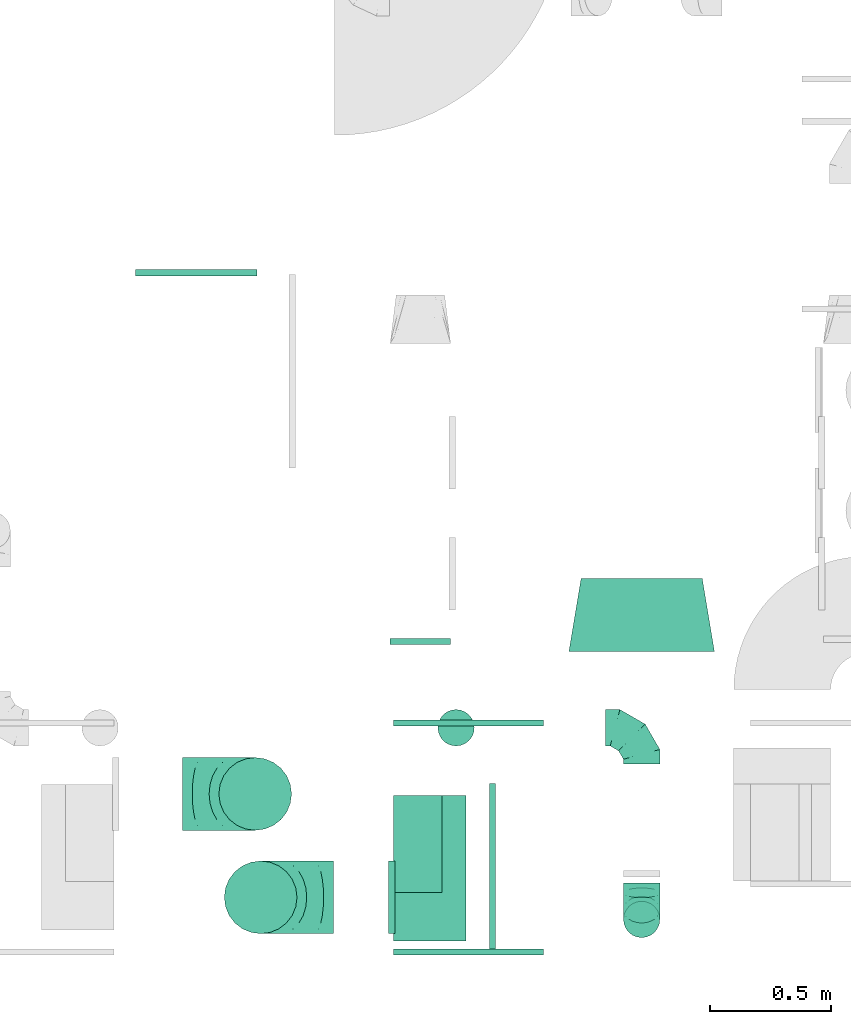
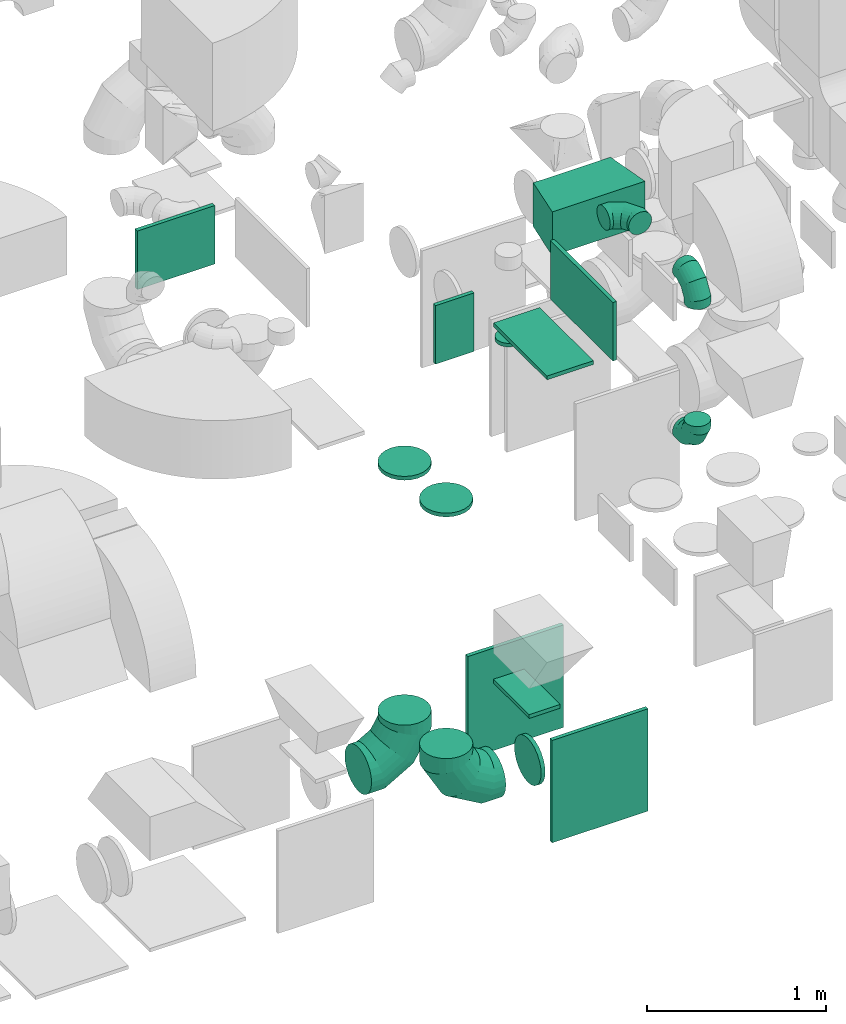
# One storey, part 22 of 59: 17 flow fittings.
"""IFC2X3 building model written with IfcOpenShell, lengths in millimetres."""

from ifc_helpers import new_model, entity, si_unit, converted_unit, derived_unit, direction, frame, origin, origin_2d_with_axis, place, context, subcontext, project, spatial, polyline, rectangle, circle, outline, extrude, faceted_brep, source, transform, mapped, material, type_object, type_shapes, element, save


model = new_model("IFC2X3")

# Units and contexts
model_context = context("Model", 3, precision=0.01, world=origin(), true_north=direction((6.12303176911189e-17, 1.0)))
body_context = subcontext(model_context, "Body", "Model", "MODEL_VIEW")
ifc_project = project(units=[si_unit("LENGTHUNIT", "METRE", prefix="MILLI"), si_unit("AREAUNIT", "SQUARE_METRE"), si_unit("VOLUMEUNIT", "CUBIC_METRE"), converted_unit("PLANEANGLEUNIT", "DEGREE", entity("IfcRatioMeasure", 0.0174532925199433), si_unit("PLANEANGLEUNIT", "RADIAN"), dimensions=[0, 0, 0, 0, 0, 0, 0]), si_unit("MASSUNIT", "GRAM", prefix="KILO"), derived_unit("MASSDENSITYUNIT", [(si_unit("MASSUNIT", "GRAM", prefix="KILO"), 1), (si_unit("LENGTHUNIT", "METRE"), -3)]), derived_unit("MOMENTOFINERTIAUNIT", [(si_unit("LENGTHUNIT", "METRE"), 4)]), si_unit("TIMEUNIT", "SECOND"), si_unit("FREQUENCYUNIT", "HERTZ"), si_unit("THERMODYNAMICTEMPERATUREUNIT", "DEGREE_CELSIUS"), derived_unit("THERMALTRANSMITTANCEUNIT", [(si_unit("MASSUNIT", "GRAM", prefix="KILO"), 1), (si_unit("THERMODYNAMICTEMPERATUREUNIT", "KELVIN"), -1), (si_unit("TIMEUNIT", "SECOND"), -3)]), derived_unit("VOLUMETRICFLOWRATEUNIT", [(si_unit("LENGTHUNIT", "METRE"), 3), (si_unit("TIMEUNIT", "SECOND"), -1)]), derived_unit("MASSFLOWRATEUNIT", [(si_unit("MASSUNIT", "GRAM", prefix="KILO"), 1), (si_unit("TIMEUNIT", "SECOND"), -1)]), derived_unit("ROTATIONALFREQUENCYUNIT", [(si_unit("TIMEUNIT", "SECOND"), -1)]), si_unit("ELECTRICCURRENTUNIT", "AMPERE"), si_unit("ELECTRICVOLTAGEUNIT", "VOLT"), si_unit("POWERUNIT", "WATT"), si_unit("FORCEUNIT", "NEWTON", prefix="KILO"), si_unit("ILLUMINANCEUNIT", "LUX"), si_unit("LUMINOUSFLUXUNIT", "LUMEN"), si_unit("LUMINOUSINTENSITYUNIT", "CANDELA"), derived_unit("USERDEFINED", [(si_unit("MASSUNIT", "GRAM", prefix="KILO"), -1), (si_unit("LENGTHUNIT", "METRE"), -2), (si_unit("TIMEUNIT", "SECOND"), 3), (si_unit("LUMINOUSFLUXUNIT", "LUMEN"), 1)]), derived_unit("LINEARVELOCITYUNIT", [(si_unit("LENGTHUNIT", "METRE"), 1), (si_unit("TIMEUNIT", "SECOND"), -1)]), si_unit("PRESSUREUNIT", "PASCAL"), derived_unit("USERDEFINED", [(si_unit("LENGTHUNIT", "METRE"), -2), (si_unit("MASSUNIT", "GRAM", prefix="KILO"), 1), (si_unit("TIMEUNIT", "SECOND"), -2)]), derived_unit("LINEARFORCEUNIT", [(si_unit("MASSUNIT", "GRAM", prefix="KILO"), 1), (si_unit("LENGTHUNIT", "METRE"), 1), (si_unit("TIMEUNIT", "SECOND"), -2), (si_unit("LENGTHUNIT", "METRE"), -1)]), derived_unit("PLANARFORCEUNIT", [(si_unit("MASSUNIT", "GRAM", prefix="KILO"), 1), (si_unit("LENGTHUNIT", "METRE"), 1), (si_unit("TIMEUNIT", "SECOND"), -2), (si_unit("LENGTHUNIT", "METRE"), -2)])], contexts=[model_context])

# Site, building, storey
site_placement = place(None, origin())
site = spatial("IfcSite", under=ifc_project, at=site_placement, CompositionType="ELEMENT")
building_placement = place(site_placement, origin())
building = spatial("IfcBuilding", under=site, at=building_placement, CompositionType="ELEMENT")
storey_placement = place(building_placement, frame((0.0, 0.0, 28200.0)))
storey = spatial("IfcBuildingStorey", under=building, at=storey_placement, CompositionType="ELEMENT", Elevation=28200.0)

# Flow fittings
ifc_material = material()
duct_fitting_type_1 = type_object("IfcDuctFittingType", PredefinedType="NOTDEFINED", material=ifc_material)
shared_shape_1 = source(origin(), body_context, "Body", "SweptSolid", [
    extrude(rectangle(XDim=200.0, YDim=26.096, at=origin_2d_with_axis()), frame((6.95, 0.0, -200.0), z_axis=(0.0, 0.0, 1.0), x_axis=(0.0, -1.0, 0.0)), (0.0, 0.0, 1.0), 400.0),
])
type_shapes(duct_fitting_type_1, [shared_shape_1])
flow_fitting_1_placement = place(storey_placement, frame((53463.63, 8360.0, 900.0), z_axis=(0.0, -1.0, 0.0), x_axis=(0.0, 0.0, 1.0)))
element("IfcFlowFitting", 1, at=flow_fitting_1_placement, inside=storey, type_object=duct_fitting_type_1, material=ifc_material, context=body_context, shape_type="MappedRepresentation", body=[
    mapped(shared_shape_1, transform((0.0, 0.0, 0.0), scale=1.0)),
])
duct_fitting_type_2 = type_object("IfcDuctFittingType", PredefinedType="NOTDEFINED", material=ifc_material)
shared_shape_2 = source(origin(), body_context, "Body", "SweptSolid", [
    extrude(outline(polyline([(-197.28, -271.26), (106.86, -271.26), (189.06, 221.94), (-98.64, 320.58), (-197.28, -271.26)])), frame((150.0, 0.0, -150.0), z_axis=(0.0, 0.0, 1.0), x_axis=(0.986393923832144, 0.164398987305356, 0.0)), (0.0, 0.0, 1.0), 300.0),
])
type_shapes(duct_fitting_type_2, [shared_shape_2])
flow_fitting_2_placement = place(storey_placement, frame((54388.0, 9155.5, 3350.0), z_axis=(0.0, 0.0, 1.0), x_axis=(0.0, 1.0, 0.0)))
element("IfcFlowFitting", 2, at=flow_fitting_2_placement, inside=storey, type_object=duct_fitting_type_2, material=ifc_material, context=body_context, shape_type="MappedRepresentation", body=[
    mapped(shared_shape_2, transform((0.0, 0.0, 0.0), scale=1.0)),
])
duct_fitting_type_3 = type_object("IfcDuctFittingType", PredefinedType="NOTDEFINED", material=ifc_material)
shared_shape_3 = source(origin(), body_context, "Body", "SweptSolid", [
    extrude(rectangle(XDim=300.0, YDim=26.0960000000433, at=origin_2d_with_axis()), frame((6.95, 0.0, -300.0), z_axis=(0.0, 0.0, 1.0), x_axis=(0.0, -1.0, 0.0)), (0.0, 0.0, 1.0), 600.0),
])
type_shapes(duct_fitting_type_3, [shared_shape_3])
flow_fitting_3_placement = place(storey_placement, frame((53513.63, 8260.0, 3350.0), z_axis=(0.0, 1.0, 0.0), x_axis=(0.0, 0.0, -1.0)))
element("IfcFlowFitting", 3, at=flow_fitting_3_placement, inside=storey, type_object=duct_fitting_type_3, material=ifc_material, context=body_context, shape_type="MappedRepresentation", body=[
    mapped(shared_shape_3, transform((0.0, 0.0, 0.0), scale=1.0)),
])
duct_fitting_type_4 = type_object("IfcDuctFittingType", PredefinedType="NOTDEFINED", material=ifc_material)
shared_shape_4 = source(origin(), body_context, "Body", "SweptSolid", [
    extrude(rectangle(XDim=24.9999999999999, YDim=620.0, at=origin_2d_with_axis()), frame((12.5, 0.0, -350.0)), (0.0, 0.0, 1.0), 700.0),
])
type_shapes(duct_fitting_type_4, [shared_shape_4])
flow_fitting_4_placement = place(storey_placement, frame((53673.63, 8847.0, 550.0), z_axis=(0.0, 0.0, 1.0), x_axis=(0.0, 1.0, 0.0)))
element("IfcFlowFitting", 4, at=flow_fitting_4_placement, inside=storey, type_object=duct_fitting_type_4, material=ifc_material, context=body_context, shape_type="MappedRepresentation", body=[
    mapped(shared_shape_4, transform((0.0, 0.0, 0.0), scale=1.0)),
])
duct_fitting_type_5 = type_object("IfcDuctFittingType", PredefinedType="NOTDEFINED", material=ifc_material)
shared_shape_5 = source(origin(), body_context, "Body", "SweptSolid", [
    extrude(rectangle(XDim=620.0, YDim=24.9999999999999, at=origin_2d_with_axis()), frame((12.5, 0.0, -350.0), z_axis=(0.0, 0.0, 1.0), x_axis=(0.0, -1.0, 0.0)), (0.0, 0.0, 1.0), 700.0),
])
type_shapes(duct_fitting_type_5, [shared_shape_5])
flow_fitting_5_placement = place(storey_placement, frame((53673.63, 7927.0, 550.0), z_axis=(0.0, 0.0, 1.0), x_axis=(0.0, -1.0, 0.0)))
element("IfcFlowFitting", 5, at=flow_fitting_5_placement, inside=storey, type_object=duct_fitting_type_5, material=ifc_material, context=body_context, shape_type="MappedRepresentation", body=[
    mapped(shared_shape_5, transform((0.0, 0.0, 0.0), scale=1.0)),
])
duct_fitting_type_6 = type_object("IfcDuctFittingType", PredefinedType="NOTDEFINED", material=ifc_material)
shared_shape_6 = source(origin(), body_context, "Body", "SweptSolid", [
    extrude(rectangle(XDim=24.9999999999999, YDim=700.0, at=origin_2d_with_axis()), frame((12.5, 0.0, -200.0)), (0.0, 0.0, 1.0), 400.0),
])
type_shapes(duct_fitting_type_6, [shared_shape_6])
flow_fitting_6_placement = place(storey_placement, frame((53760.61, 8260.0, 3550.0)))
element("IfcFlowFitting", 6, at=flow_fitting_6_placement, inside=storey, type_object=duct_fitting_type_6, material=ifc_material, context=body_context, shape_type="MappedRepresentation", body=[
    mapped(shared_shape_6, transform((0.0, 0.0, 0.0), scale=1.0)),
])
duct_fitting_type_7 = type_object("IfcDuctFittingType", PredefinedType="NOTDEFINED", material=ifc_material)
shared_shape_7 = source(origin(), body_context, "Body", "SweptSolid", [
    extrude(circle(Radius=74.9999999999995, at=origin_2d_with_axis()), frame((0.0, 0.0, 0.0), z_axis=(1.0, 0.0, 0.0), x_axis=(0.0, 1.0, 0.0)), (0.0, 0.0, 1.0), 25.0000000000018),
])
type_shapes(duct_fitting_type_7, [shared_shape_7])
flow_fitting_7_placement = place(storey_placement, frame((53622.36, 8840.5, 3008.0), z_axis=(0.0, -1.0, 0.0), x_axis=(0.0, 0.0, -1.0)))
element("IfcFlowFitting", 7, at=flow_fitting_7_placement, inside=storey, type_object=duct_fitting_type_7, material=ifc_material, context=body_context, shape_type="MappedRepresentation", body=[
    mapped(shared_shape_7, transform((0.0, 0.0, 0.0), scale=1.0)),
])
duct_fitting_type_8 = type_object("IfcDuctFittingType", PredefinedType="NOTDEFINED", material=ifc_material)
shared_shape_8 = source(origin(), body_context, "Body", "SweptSolid", [
    extrude(rectangle(XDim=24.9999999999999, YDim=250.0, at=origin_2d_with_axis()), frame((12.5, 0.0, -200.0)), (0.0, 0.0, 1.0), 400.0),
])
type_shapes(duct_fitting_type_8, [shared_shape_8])
flow_fitting_8_placement = place(storey_placement, frame((53475.03, 9209.24, 2900.0), z_axis=(0.0, 0.0, 1.0), x_axis=(0.0, -1.0, 0.0)))
element("IfcFlowFitting", 8, at=flow_fitting_8_placement, inside=storey, type_object=duct_fitting_type_8, material=ifc_material, context=body_context, shape_type="MappedRepresentation", body=[
    mapped(shared_shape_8, transform((0.0, 0.0, 0.0), scale=1.0)),
])
duct_fitting_type_9 = type_object("IfcDuctFittingType", PredefinedType="NOTDEFINED", material=ifc_material)
shared_shape_9 = source(origin(), body_context, "Body", "SweptSolid", [
    extrude(rectangle(XDim=26.0960000000051, YDim=500.0, at=origin_2d_with_axis()), frame((6.95, 0.0, -200.0)), (0.0, 0.0, 1.0), 400.0),
])
type_shapes(duct_fitting_type_9, [shared_shape_9])
flow_fitting_9_placement = place(storey_placement, frame((52550.35, 10711.5, 2855.02), z_axis=(0.0, 0.0, -1.0), x_axis=(0.0, 1.0, 0.0)))
element("IfcFlowFitting", 9, at=flow_fitting_9_placement, inside=storey, type_object=duct_fitting_type_9, material=ifc_material, context=body_context, shape_type="MappedRepresentation", body=[
    mapped(shared_shape_9, transform((0.0, 0.0, 0.0), scale=1.0)),
])
duct_fitting_type_10 = type_object("IfcDuctFittingType", PredefinedType="NOTDEFINED", material=ifc_material)
shared_shape_10 = source(origin(), body_context, "Body", "Brep", [
    faceted_brep([(-300.0, 0.0, -150.0), (-300.0, -38.82, -144.89), (-300.0, -75.0, -129.9), (-300.0, -106.07, -106.07), (-300.0, -129.9, -75.0), (-300.0, -144.89, -38.82), (-300.0, -150.0, 0.0), (-300.0, -144.89, 38.82), (-300.0, -129.9, 75.0), (-300.0, -106.07, 106.07), (-300.0, -75.0, 129.9), (-300.0, -38.82, 144.89), (-300.0, 0.0, 150.0), (-300.0, 38.82, 144.89), (-300.0, 75.0, 129.9), (-300.0, 106.07, 106.07), (-300.0, 129.9, 75.0), (-300.0, 144.89, 38.82), (-300.0, 150.0, 0.0), (-300.0, 144.89, -38.82), (-300.0, 129.9, -75.0), (-300.0, 106.07, -106.07), (-300.0, 75.0, -129.9), (-300.0, 38.82, -144.89), (-230.02, 38.82, 144.89), (-239.71, 75.0, 129.9), (-219.62, 0.0, 150.0), (-248.04, 106.07, 106.07), (-258.44, 144.89, 38.82), (-259.81, 150.0, 0.0), (-254.42, 129.9, 75.0), (-254.42, 129.9, -75.0), (-248.04, 106.07, -106.07), (-258.44, 144.89, -38.82), (-230.02, 38.82, -144.89), (-219.62, 0.0, -150.0), (-239.71, 75.0, -129.9), (-209.21, -38.82, -144.89), (-199.52, -75.0, -129.9), (-191.19, -106.07, -106.07), (-184.81, -129.9, -75.0), (-180.79, -144.89, -38.82), (-179.42, -150.0, 0.0), (-180.79, -144.89, 38.82), (-184.81, -129.9, 75.0), (-191.19, -106.07, 106.07), (-199.52, -75.0, 129.9), (-209.21, -38.82, 144.89), (-108.81, 108.81, 144.89), (-135.29, 135.29, 129.9), (-80.38, 80.38, 150.0), (-158.03, 158.03, 106.07), (-175.48, 175.48, 75.0), (-186.45, 186.45, 38.82), (-190.19, 190.19, 0.0), (-186.45, 186.45, -38.82), (-175.48, 175.48, -75.0), (-158.03, 158.03, -106.07), (-108.81, 108.81, -144.89), (-80.38, 80.38, -150.0), (-135.29, 135.29, -129.9), (-51.96, 51.96, -144.89), (-25.48, 25.48, -129.9), (-2.74, 2.74, -106.07), (14.71, -14.71, -75.0), (25.68, -25.68, -38.82), (29.42, -29.42, 0.0), (25.68, -25.68, 38.82), (14.71, -14.71, 75.0), (-2.74, 2.74, 106.07), (-25.48, 25.48, 129.9), (-51.96, 51.96, 144.89), (-38.82, 230.02, 144.89), (-75.0, 239.71, 129.9), (0.0, 219.62, 150.0), (-106.07, 248.04, 106.07), (-129.9, 254.42, 75.0), (-144.89, 258.44, 38.82), (-150.0, 259.81, 0.0), (-144.89, 258.44, -38.82), (-129.9, 254.42, -75.0), (-106.07, 248.04, -106.07), (-38.82, 230.02, -144.89), (0.0, 219.62, -150.0), (-75.0, 239.71, -129.9), (38.82, 209.21, -144.89), (75.0, 199.52, -129.9), (106.07, 191.19, -106.07), (129.9, 184.81, -75.0), (144.89, 180.79, -38.82), (150.0, 179.42, 0.0), (144.89, 180.79, 38.82), (129.9, 184.81, 75.0), (106.07, 191.19, 106.07), (75.0, 199.52, 129.9), (38.82, 209.21, 144.89), (-150.0, 300.0, 0.0), (-144.89, 300.0, 38.82), (-129.9, 300.0, 75.0), (-106.07, 300.0, 106.07), (-75.0, 300.0, 129.9), (-38.82, 300.0, 144.89), (0.0, 300.0, 150.0), (38.82, 300.0, 144.89), (75.0, 300.0, 129.9), (106.07, 300.0, 106.07), (129.9, 300.0, 75.0), (144.89, 300.0, 38.82), (150.0, 300.0, 0.0), (144.89, 300.0, -38.82), (129.9, 300.0, -75.0), (106.07, 300.0, -106.07), (75.0, 300.0, -129.9), (38.82, 300.0, -144.89), (0.0, 300.0, -150.0), (-38.82, 300.0, -144.89), (-75.0, 300.0, -129.9), (-106.07, 300.0, -106.07), (-129.9, 300.0, -75.0), (-144.89, 300.0, -38.82)], [[[0, 1, 2, 3, 4, 5, 6, 7, 8, 9, 10, 11, 12, 13, 14, 15, 16, 17, 18, 19, 20, 21, 22, 23]], [[24, 25, 14, 13]], [[26, 24, 13, 12]], [[14, 25, 27, 15]], [[28, 29, 18, 17]], [[30, 28, 17, 16]], [[15, 27, 30, 16]], [[20, 31, 32, 21]], [[33, 31, 20, 19]], [[18, 29, 33, 19]], [[34, 35, 0, 23]], [[36, 34, 23, 22]], [[32, 36, 22, 21]], [[1, 0, 35, 37]], [[2, 1, 37, 38]], [[38, 39, 3, 2]], [[5, 4, 40, 41]], [[6, 5, 41, 42]], [[39, 40, 4, 3]], [[6, 42, 43, 7]], [[7, 43, 44, 8]], [[8, 44, 45, 9]], [[9, 45, 46, 10]], [[10, 46, 47, 11]], [[26, 12, 11, 47]], [[48, 49, 25, 24]], [[50, 48, 24, 26]], [[27, 25, 49, 51]], [[52, 53, 28, 30]], [[51, 52, 30, 27]], [[29, 28, 53, 54]], [[55, 56, 31, 33]], [[54, 55, 33, 29]], [[32, 31, 56, 57]], [[58, 59, 35, 34]], [[60, 58, 34, 36]], [[57, 60, 36, 32]], [[37, 35, 59, 61]], [[38, 37, 61, 62]], [[39, 38, 62, 63]], [[41, 40, 64, 65]], [[42, 41, 65, 66]], [[63, 64, 40, 39]], [[43, 42, 66, 67]], [[44, 43, 67, 68]], [[68, 69, 45, 44]], [[46, 45, 69, 70]], [[47, 46, 70, 71]], [[26, 47, 71, 50]], [[72, 73, 49, 48]], [[74, 72, 48, 50]], [[51, 49, 73, 75]], [[76, 77, 53, 52]], [[75, 76, 52, 51]], [[54, 53, 77, 78]], [[79, 80, 56, 55]], [[78, 79, 55, 54]], [[57, 56, 80, 81]], [[82, 83, 59, 58]], [[84, 82, 58, 60]], [[81, 84, 60, 57]], [[61, 59, 83, 85]], [[62, 61, 85, 86]], [[63, 62, 86, 87]], [[65, 64, 88, 89]], [[66, 65, 89, 90]], [[87, 88, 64, 63]], [[67, 66, 90, 91]], [[68, 67, 91, 92]], [[92, 93, 69, 68]], [[70, 69, 93, 94]], [[71, 70, 94, 95]], [[50, 71, 95, 74]], [[96, 97, 98, 99, 100, 101, 102, 103, 104, 105, 106, 107, 108, 109, 110, 111, 112, 113, 114, 115, 116, 117, 118, 119]], [[101, 100, 73, 72]], [[102, 101, 72, 74]], [[75, 73, 100, 99]], [[77, 76, 98, 97]], [[78, 77, 97, 96]], [[99, 98, 76, 75]], [[119, 118, 80, 79]], [[96, 119, 79, 78]], [[117, 81, 80, 118]], [[84, 116, 115, 82]], [[82, 115, 114, 83]], [[116, 84, 81, 117]], [[83, 114, 113, 85]], [[85, 113, 112, 86]], [[111, 87, 86, 112]], [[88, 110, 109, 89]], [[89, 109, 108, 90]], [[110, 88, 87, 111]], [[91, 90, 108, 107]], [[92, 91, 107, 106]], [[106, 105, 93, 92]], [[95, 94, 104, 103]], [[74, 95, 103, 102]], [[105, 104, 94, 93]]]),
])
type_shapes(duct_fitting_type_10, [shared_shape_10])
for number, where, z_axis, x_axis in (
    (10, (52793.38, 8567.36, 605.29), (0.0, -1.0, 0.0), (1.0, 0.0, 0.0)),
    (11, (52815.87, 8140.67, 627.5), (0.0, -1.0, 0.0), (0.0, 0.0, -1.0)),
):
    element("IfcFlowFitting", number, at=place(storey_placement, frame(where, z_axis=z_axis, x_axis=x_axis)), inside=storey, type_object=duct_fitting_type_10, material=ifc_material, context=body_context, shape_type="MappedRepresentation", body=[
        mapped(shared_shape_10, transform((0.0, 0.0, 0.0), scale=1.0)),
    ])
duct_fitting_type_11 = type_object("IfcDuctFittingType", PredefinedType="NOTDEFINED", material=ifc_material)
shared_shape_11 = source(origin(), body_context, "Body", "Brep", [
    faceted_brep([(20.0, 0.0, -150.0), (20.0, 38.82, -144.89), (20.0, 75.0, -129.9), (20.0, 106.07, -106.07), (20.0, 129.9, -75.0), (20.0, 144.89, -38.82), (20.0, 150.0, 0.0), (20.0, 144.89, 38.82), (20.0, 129.9, 75.0), (20.0, 106.07, 106.07), (20.0, 75.0, 129.9), (20.0, 38.82, 144.89), (20.0, 0.0, 150.0), (20.0, -38.82, 144.89), (20.0, -75.0, 129.9), (20.0, -106.07, 106.07), (20.0, -129.9, 75.0), (20.0, -144.89, 38.82), (20.0, -150.0, 0.0), (20.0, -144.89, -38.82), (20.0, -129.9, -75.0), (20.0, -106.07, -106.07), (20.0, -75.0, -129.9), (20.0, -38.82, -144.89), (0.0, 0.0, 150.0), (-6.1, 0.0, 150.0), (-6.1, -38.82, 144.89), (0.0, -38.82, 144.89), (-6.1, -75.0, 129.9), (0.0, -75.0, 129.9), (0.0, -106.07, 106.07), (-6.1, -106.07, 106.07), (0.0, -129.9, 75.0), (-6.1, -129.9, 75.0), (-6.1, -144.89, 38.82), (0.0, -144.89, 38.82), (-6.1, -150.0, 0.0), (0.0, -150.0, 0.0), (-6.1, -144.89, -38.82), (0.0, -144.89, -38.82), (-6.1, -129.9, -75.0), (0.0, -129.9, -75.0), (0.0, -106.07, -106.07), (-6.1, -106.07, -106.07), (0.0, -75.0, -129.9), (-6.1, -75.0, -129.9), (-6.1, -38.82, -144.89), (0.0, -38.82, -144.89), (-6.1, 0.0, -150.0), (0.0, 0.0, -150.0), (-6.1, 38.82, -144.89), (0.0, 38.82, -144.89), (-6.1, 75.0, -129.9), (0.0, 75.0, -129.9), (0.0, 106.07, -106.07), (-6.1, 106.07, -106.07), (0.0, 129.9, -75.0), (-6.1, 129.9, -75.0), (-6.1, 144.89, -38.82), (0.0, 144.89, -38.82), (-6.1, 150.0, 0.0), (0.0, 150.0, 0.0), (-6.1, 144.89, 38.82), (0.0, 144.89, 38.82), (-6.1, 129.9, 75.0), (0.0, 129.9, 75.0), (0.0, 106.07, 106.07), (-6.1, 106.07, 106.07), (0.0, 75.0, 129.9), (-6.1, 75.0, 129.9), (-6.1, 38.82, 144.89), (0.0, 38.82, 144.89)], [[[0, 1, 2, 3, 4, 5, 6, 7, 8, 9, 10, 11, 12, 13, 14, 15, 16, 17, 18, 19, 20, 21, 22, 23]], [[13, 12, 24, 25, 26, 27]], [[14, 13, 27, 26, 28, 29]], [[30, 15, 14, 29, 28, 31]], [[17, 16, 32, 33, 34, 35]], [[18, 17, 35, 34, 36, 37]], [[32, 16, 15, 30, 31, 33]], [[19, 18, 37, 36, 38, 39]], [[20, 19, 39, 38, 40, 41]], [[42, 21, 20, 41, 40, 43]], [[23, 22, 44, 45, 46, 47]], [[0, 23, 47, 46, 48, 49]], [[44, 22, 21, 42, 43, 45]], [[1, 0, 49, 48, 50, 51]], [[2, 1, 51, 50, 52, 53]], [[54, 3, 2, 53, 52, 55]], [[5, 4, 56, 57, 58, 59]], [[6, 5, 59, 58, 60, 61]], [[56, 4, 3, 54, 55, 57]], [[7, 6, 61, 60, 62, 63]], [[8, 7, 63, 62, 64, 65]], [[66, 9, 8, 65, 64, 67]], [[11, 10, 68, 69, 70, 71]], [[12, 11, 71, 70, 25, 24]], [[68, 10, 9, 66, 67, 69]], [[46, 45, 43, 40, 38, 36, 34, 33, 31, 28, 26, 25, 70, 69, 67, 64, 62, 60, 58, 57, 55, 52, 50, 48]]]),
])
type_shapes(duct_fitting_type_11, [shared_shape_11])
for number, where, z_axis, x_axis in (
    (12, (52793.38, 8567.36, 2600.0), (0.0, 1.0, 0.0), (0.0, 0.0, -1.0)),
    (13, (52815.87, 8140.67, 2600.0), (0.0, 1.0, 0.0), (0.0, 0.0, -1.0)),
):
    element("IfcFlowFitting", number, at=place(storey_placement, frame(where, z_axis=z_axis, x_axis=x_axis)), inside=storey, type_object=duct_fitting_type_11, material=ifc_material, context=body_context, shape_type="MappedRepresentation", body=[
        mapped(shared_shape_11, transform((0.0, 0.0, 0.0), scale=1.0)),
    ])
duct_fitting_type_12 = type_object("IfcDuctFittingType", PredefinedType="NOTDEFINED", material=ifc_material)
shared_shape_12 = source(origin(), body_context, "Body", "Brep", [
    faceted_brep([(20.0, 38.82, -144.89), (20.0, 75.0, -129.9), (20.0, 106.07, -106.07), (20.0, 129.9, -75.0), (20.0, 144.89, -38.82), (20.0, 150.0, 0.0), (20.0, 144.89, 38.82), (20.0, 129.9, 75.0), (20.0, 106.07, 106.07), (20.0, 75.0, 129.9), (20.0, 38.82, 144.89), (20.0, 0.0, 150.0), (20.0, -38.82, 144.89), (20.0, -75.0, 129.9), (20.0, -106.07, 106.07), (20.0, -129.9, 75.0), (20.0, -144.89, 38.82), (20.0, -150.0, 0.0), (20.0, -144.89, -38.82), (20.0, -129.9, -75.0), (20.0, -106.07, -106.07), (20.0, -75.0, -129.9), (20.0, -38.82, -144.89), (20.0, 0.0, -150.0), (0.0, 0.0, 150.0), (0.0, 38.82, 144.89), (-6.1, 38.82, 144.89), (-6.1, 0.0, 150.0), (0.0, 75.0, 129.9), (-6.1, 75.0, 129.9), (0.0, 106.07, 106.07), (-6.1, 106.07, 106.07), (0.0, 129.9, 75.0), (0.0, 144.89, 38.82), (-6.1, 144.89, 38.82), (-6.1, 129.9, 75.0), (0.0, 150.0, 0.0), (-6.1, 150.0, 0.0), (0.0, 144.89, -38.82), (-6.1, 144.89, -38.82), (0.0, 129.9, -75.0), (-6.1, 129.9, -75.0), (0.0, 106.07, -106.07), (-6.1, 106.07, -106.07), (0.0, 75.0, -129.9), (0.0, 38.82, -144.89), (-6.1, 38.82, -144.89), (-6.1, 75.0, -129.9), (0.0, 0.0, -150.0), (-6.1, 0.0, -150.0), (0.0, -38.82, -144.89), (-6.1, -38.82, -144.89), (0.0, -75.0, -129.9), (-6.1, -75.0, -129.9), (0.0, -106.07, -106.07), (-6.1, -106.07, -106.07), (0.0, -129.9, -75.0), (0.0, -144.89, -38.82), (-6.1, -144.89, -38.82), (-6.1, -129.9, -75.0), (0.0, -150.0, 0.0), (-6.1, -150.0, 0.0), (0.0, -144.89, 38.82), (-6.1, -144.89, 38.82), (0.0, -129.9, 75.0), (-6.1, -129.9, 75.0), (0.0, -106.07, 106.07), (-6.1, -106.07, 106.07), (0.0, -75.0, 129.9), (0.0, -38.82, 144.89), (-6.1, -38.82, 144.89), (-6.1, -75.0, 129.9)], [[[0, 1, 2, 3, 4, 5, 6, 7, 8, 9, 10, 11, 12, 13, 14, 15, 16, 17, 18, 19, 20, 21, 22, 23]], [[24, 11, 10, 25, 26, 27]], [[25, 10, 9, 28, 29, 26]], [[28, 9, 8, 30, 31, 29]], [[32, 7, 6, 33, 34, 35]], [[33, 6, 5, 36, 37, 34]], [[30, 8, 7, 32, 35, 31]], [[36, 5, 4, 38, 39, 37]], [[38, 4, 3, 40, 41, 39]], [[40, 3, 2, 42, 43, 41]], [[44, 1, 0, 45, 46, 47]], [[45, 0, 23, 48, 49, 46]], [[42, 2, 1, 44, 47, 43]], [[48, 23, 22, 50, 51, 49]], [[50, 22, 21, 52, 53, 51]], [[52, 21, 20, 54, 55, 53]], [[56, 19, 18, 57, 58, 59]], [[57, 18, 17, 60, 61, 58]], [[54, 20, 19, 56, 59, 55]], [[60, 17, 16, 62, 63, 61]], [[62, 16, 15, 64, 65, 63]], [[64, 15, 14, 66, 67, 65]], [[68, 13, 12, 69, 70, 71]], [[69, 12, 11, 24, 27, 70]], [[66, 14, 13, 68, 71, 67]], [[49, 51, 53, 55, 59, 58, 61, 63, 65, 67, 71, 70, 27, 26, 29, 31, 35, 34, 37, 39, 41, 43, 47, 46]]]),
])
type_shapes(duct_fitting_type_12, [shared_shape_12])
flow_fitting_10_placement = place(storey_placement, frame((53363.63, 8140.67, 627.5), z_axis=(0.0, 0.0, -1.0), x_axis=(-1.0, 0.0, 0.0)))
element("IfcFlowFitting", 14, at=flow_fitting_10_placement, inside=storey, type_object=duct_fitting_type_12, material=ifc_material, context=body_context, shape_type="MappedRepresentation", body=[
    mapped(shared_shape_12, transform((0.0, 0.0, 0.0), scale=1.0)),
])
duct_fitting_type_13 = type_object("IfcDuctFittingType", PredefinedType="NOTDEFINED", material=ifc_material)
shared_shape_13 = source(origin(), body_context, "Body", "Brep", [
    faceted_brep([(-150.0, 0.0, -75.0), (-150.0, -19.41, -72.44), (-150.0, -37.5, -64.95), (-150.0, -53.03, -53.03), (-150.0, -64.95, -37.5), (-150.0, -72.44, -19.41), (-150.0, -75.0, 0.0), (-150.0, -72.44, 19.41), (-150.0, -64.95, 37.5), (-150.0, -53.03, 53.03), (-150.0, -37.5, 64.95), (-150.0, -19.41, 72.44), (-150.0, 0.0, 75.0), (-150.0, 19.41, 72.44), (-150.0, 37.5, 64.95), (-150.0, 53.03, 53.03), (-150.0, 64.95, 37.5), (-150.0, 72.44, 19.41), (-150.0, 75.0, 0.0), (-150.0, 72.44, -19.41), (-150.0, 64.95, -37.5), (-150.0, 53.03, -53.03), (-150.0, 37.5, -64.95), (-150.0, 19.41, -72.44), (-115.01, 19.41, 72.44), (-119.86, 37.5, 64.95), (-109.81, 0.0, 75.0), (-124.02, 53.03, 53.03), (-129.22, 72.44, 19.41), (-129.9, 75.0, 0.0), (-127.21, 64.95, 37.5), (-127.21, 64.95, -37.5), (-124.02, 53.03, -53.03), (-129.22, 72.44, -19.41), (-115.01, 19.41, -72.44), (-109.81, 0.0, -75.0), (-119.86, 37.5, -64.95), (-104.61, -19.41, -72.44), (-99.76, -37.5, -64.95), (-95.6, -53.03, -53.03), (-92.4, -64.95, -37.5), (-90.4, -72.44, -19.41), (-89.71, -75.0, 0.0), (-90.4, -72.44, 19.41), (-92.4, -64.95, 37.5), (-95.6, -53.03, 53.03), (-99.76, -37.5, 64.95), (-104.61, -19.41, 72.44), (-54.4, 54.4, 72.44), (-67.64, 67.64, 64.95), (-40.19, 40.19, 75.0), (-79.02, 79.02, 53.03), (-87.74, 87.74, 37.5), (-93.23, 93.23, 19.41), (-95.1, 95.1, 0.0), (-93.23, 93.23, -19.41), (-87.74, 87.74, -37.5), (-79.02, 79.02, -53.03), (-54.4, 54.4, -72.44), (-40.19, 40.19, -75.0), (-67.64, 67.64, -64.95), (-25.98, 25.98, -72.44), (-12.74, 12.74, -64.95), (-1.37, 1.37, -53.03), (7.36, -7.36, -37.5), (12.84, -12.84, -19.41), (14.71, -14.71, 0.0), (12.84, -12.84, 19.41), (7.36, -7.36, 37.5), (-1.37, 1.37, 53.03), (-12.74, 12.74, 64.95), (-25.98, 25.98, 72.44), (-19.41, 115.01, 72.44), (-37.5, 119.86, 64.95), (0.0, 109.81, 75.0), (-53.03, 124.02, 53.03), (-64.95, 127.21, 37.5), (-72.44, 129.22, 19.41), (-75.0, 129.9, 0.0), (-72.44, 129.22, -19.41), (-64.95, 127.21, -37.5), (-53.03, 124.02, -53.03), (-19.41, 115.01, -72.44), (0.0, 109.81, -75.0), (-37.5, 119.86, -64.95), (19.41, 104.61, -72.44), (37.5, 99.76, -64.95), (53.03, 95.6, -53.03), (64.95, 92.4, -37.5), (72.44, 90.4, -19.41), (75.0, 89.71, 0.0), (72.44, 90.4, 19.41), (64.95, 92.4, 37.5), (53.03, 95.6, 53.03), (37.5, 99.76, 64.95), (19.41, 104.61, 72.44), (-19.41, 150.0, -72.44), (-37.5, 150.0, -64.95), (-53.03, 150.0, -53.03), (-64.95, 150.0, -37.5), (-72.44, 150.0, -19.41), (-75.0, 150.0, 0.0), (-72.44, 150.0, 19.41), (-64.95, 150.0, 37.5), (-53.03, 150.0, 53.03), (-37.5, 150.0, 64.95), (-19.41, 150.0, 72.44), (0.0, 150.0, 75.0), (19.41, 150.0, 72.44), (37.5, 150.0, 64.95), (53.03, 150.0, 53.03), (64.95, 150.0, 37.5), (72.44, 150.0, 19.41), (75.0, 150.0, 0.0), (72.44, 150.0, -19.41), (64.95, 150.0, -37.5), (53.03, 150.0, -53.03), (37.5, 150.0, -64.95), (19.41, 150.0, -72.44), (0.0, 150.0, -75.0)], [[[0, 1, 2, 3, 4, 5, 6, 7, 8, 9, 10, 11, 12, 13, 14, 15, 16, 17, 18, 19, 20, 21, 22, 23]], [[24, 25, 14, 13]], [[26, 24, 13, 12]], [[14, 25, 27, 15]], [[28, 29, 18, 17]], [[30, 28, 17, 16]], [[15, 27, 30, 16]], [[20, 31, 32, 21]], [[33, 31, 20, 19]], [[18, 29, 33, 19]], [[34, 35, 0, 23]], [[36, 34, 23, 22]], [[21, 32, 36, 22]], [[1, 0, 35, 37]], [[2, 1, 37, 38]], [[3, 2, 38, 39]], [[5, 4, 40, 41]], [[6, 5, 41, 42]], [[39, 40, 4, 3]], [[6, 42, 43, 7]], [[7, 43, 44, 8]], [[8, 44, 45, 9]], [[9, 45, 46, 10]], [[10, 46, 47, 11]], [[26, 12, 11, 47]], [[48, 49, 25, 24]], [[50, 48, 24, 26]], [[27, 25, 49, 51]], [[52, 53, 28, 30]], [[51, 52, 30, 27]], [[29, 28, 53, 54]], [[55, 56, 31, 33]], [[54, 55, 33, 29]], [[32, 31, 56, 57]], [[58, 59, 35, 34]], [[60, 58, 34, 36]], [[57, 60, 36, 32]], [[37, 35, 59, 61]], [[38, 37, 61, 62]], [[39, 38, 62, 63]], [[41, 40, 64, 65]], [[42, 41, 65, 66]], [[63, 64, 40, 39]], [[43, 42, 66, 67]], [[44, 43, 67, 68]], [[68, 69, 45, 44]], [[46, 45, 69, 70]], [[47, 46, 70, 71]], [[26, 47, 71, 50]], [[72, 73, 49, 48]], [[74, 72, 48, 50]], [[51, 49, 73, 75]], [[76, 77, 53, 52]], [[75, 76, 52, 51]], [[54, 53, 77, 78]], [[79, 80, 56, 55]], [[78, 79, 55, 54]], [[57, 56, 80, 81]], [[82, 83, 59, 58]], [[84, 82, 58, 60]], [[81, 84, 60, 57]], [[61, 59, 83, 85]], [[62, 61, 85, 86]], [[63, 62, 86, 87]], [[65, 64, 88, 89]], [[66, 65, 89, 90]], [[87, 88, 64, 63]], [[67, 66, 90, 91]], [[68, 67, 91, 92]], [[92, 93, 69, 68]], [[70, 69, 93, 94]], [[71, 70, 94, 95]], [[50, 71, 95, 74]], [[96, 97, 98, 99, 100, 101, 102, 103, 104, 105, 106, 107, 108, 109, 110, 111, 112, 113, 114, 115, 116, 117, 118, 119]], [[72, 74, 107, 106]], [[73, 72, 106, 105]], [[75, 73, 105, 104]], [[77, 76, 103, 102]], [[78, 77, 102, 101]], [[75, 104, 103, 76]], [[78, 101, 100, 79]], [[79, 100, 99, 80]], [[80, 99, 98, 81]], [[84, 97, 96, 82]], [[82, 96, 119, 83]], [[84, 81, 98, 97]], [[83, 119, 118, 85]], [[85, 118, 117, 86]], [[116, 87, 86, 117]], [[88, 115, 114, 89]], [[89, 114, 113, 90]], [[115, 88, 87, 116]], [[112, 111, 92, 91]], [[113, 112, 91, 90]], [[111, 110, 93, 92]], [[95, 94, 109, 108]], [[74, 95, 108, 107]], [[110, 109, 94, 93]]]),
])
type_shapes(duct_fitting_type_13, [shared_shape_13])
for number, where, z_axis, x_axis in (
    (15, (54388.0, 8049.5, 2500.0), (-1.0, 0.0, 0.0), (0.0, -1.0, 0.0)),
    (16, (54388.0, 8049.5, 3600.0), (-1.0, 0.0, 0.0), (0.0, 0.0, 1.0)),
    (17, (54388.0, 8840.5, 3600.0), (0.0, 0.0, 1.0), (0.0, 1.0, 0.0)),
):
    element("IfcFlowFitting", number, at=place(storey_placement, frame(where, z_axis=z_axis, x_axis=x_axis)), inside=storey, type_object=duct_fitting_type_13, material=ifc_material, context=body_context, shape_type="MappedRepresentation", body=[
        mapped(shared_shape_13, transform((0.0, 0.0, 0.0), scale=1.0)),
    ])

save(model, "model.ifc")
